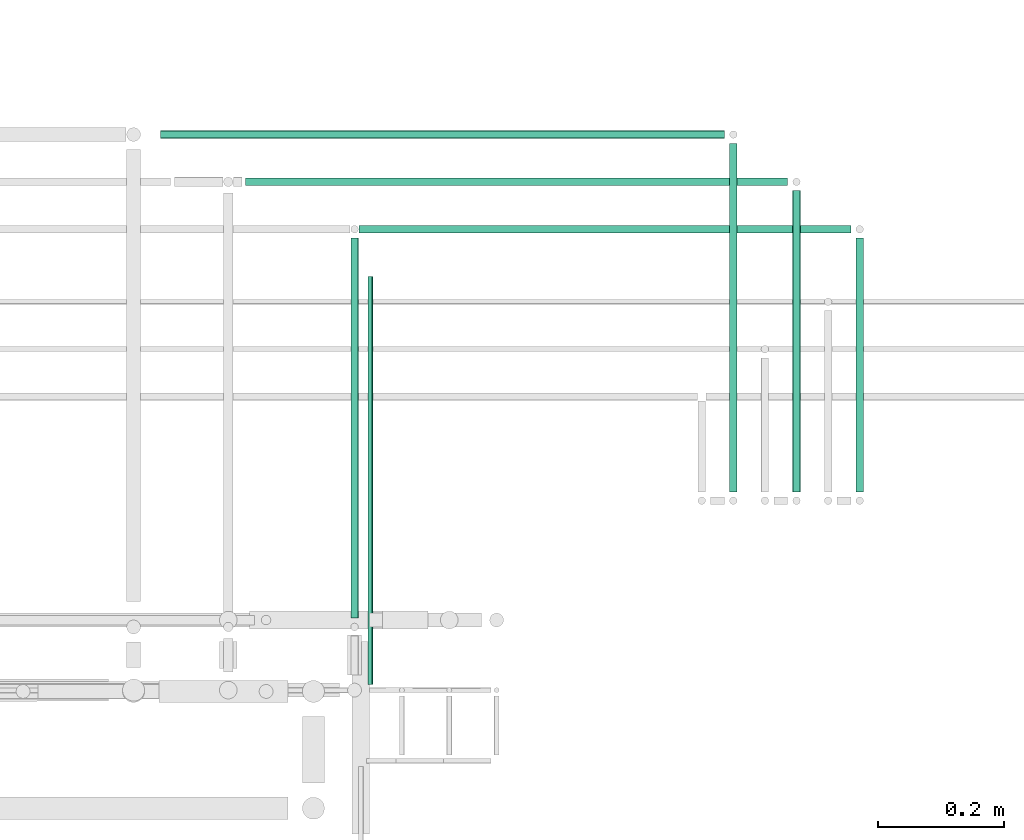
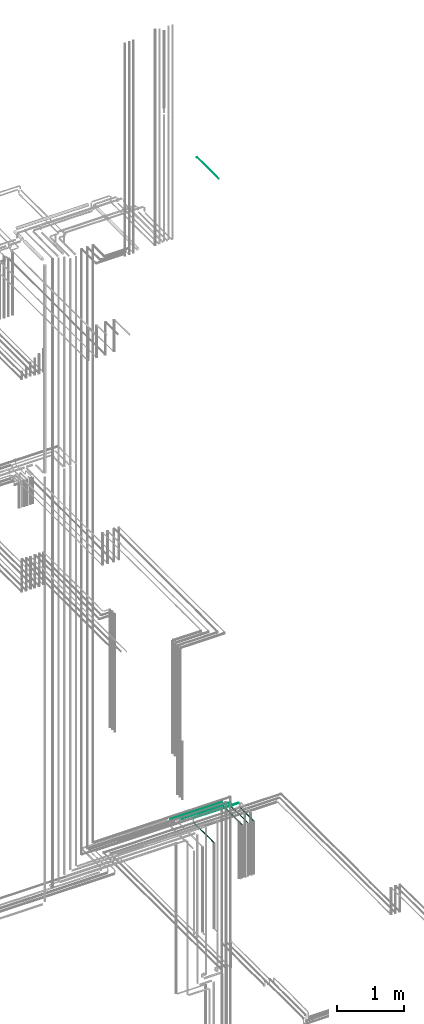
# One storey, part 236 of 331: 8 flow segments.
"""IFC2X3 building model written with IfcOpenShell, lengths in millimetres."""

from ifc_helpers import new_model, entity, si_unit, converted_unit, derived_unit, direction, frame, frame_2d, origin, origin_2d_with_axis, place, context, subcontext, project, spatial, circle, extrude, type_object, element, save


model = new_model("IFC2X3")

# Units and contexts
model_context = context("Model", 3, precision=0.01, world=origin(), true_north=direction((6.12303176911189e-17, 1.0)))
body_context = subcontext(model_context, "Body", "Model", "MODEL_VIEW")
ifc_project = project(units=[si_unit("LENGTHUNIT", "METRE", prefix="MILLI"), si_unit("AREAUNIT", "SQUARE_METRE"), si_unit("VOLUMEUNIT", "CUBIC_METRE"), converted_unit("PLANEANGLEUNIT", "DEGREE", entity("IfcRatioMeasure", 0.0174532925199433), si_unit("PLANEANGLEUNIT", "RADIAN"), dimensions=[0, 0, 0, 0, 0, 0, 0]), si_unit("MASSUNIT", "GRAM", prefix="KILO"), derived_unit("MASSDENSITYUNIT", [(si_unit("MASSUNIT", "GRAM", prefix="KILO"), 1), (si_unit("LENGTHUNIT", "METRE"), -3)]), derived_unit("MOMENTOFINERTIAUNIT", [(si_unit("LENGTHUNIT", "METRE"), 4)]), si_unit("TIMEUNIT", "SECOND"), si_unit("FREQUENCYUNIT", "HERTZ"), si_unit("THERMODYNAMICTEMPERATUREUNIT", "DEGREE_CELSIUS"), derived_unit("THERMALTRANSMITTANCEUNIT", [(si_unit("MASSUNIT", "GRAM", prefix="KILO"), 1), (si_unit("THERMODYNAMICTEMPERATUREUNIT", "KELVIN"), -1), (si_unit("TIMEUNIT", "SECOND"), -3)]), derived_unit("VOLUMETRICFLOWRATEUNIT", [(si_unit("LENGTHUNIT", "METRE"), 3), (si_unit("TIMEUNIT", "SECOND"), -1)]), derived_unit("MASSFLOWRATEUNIT", [(si_unit("MASSUNIT", "GRAM", prefix="KILO"), 1), (si_unit("TIMEUNIT", "SECOND"), -1)]), derived_unit("ROTATIONALFREQUENCYUNIT", [(si_unit("TIMEUNIT", "SECOND"), -1)]), si_unit("ELECTRICCURRENTUNIT", "AMPERE"), si_unit("ELECTRICVOLTAGEUNIT", "VOLT"), si_unit("POWERUNIT", "WATT"), si_unit("FORCEUNIT", "NEWTON", prefix="KILO"), si_unit("ILLUMINANCEUNIT", "LUX"), si_unit("LUMINOUSFLUXUNIT", "LUMEN"), si_unit("LUMINOUSINTENSITYUNIT", "CANDELA"), derived_unit("USERDEFINED", [(si_unit("MASSUNIT", "GRAM", prefix="KILO"), -1), (si_unit("LENGTHUNIT", "METRE"), -2), (si_unit("TIMEUNIT", "SECOND"), 3), (si_unit("LUMINOUSFLUXUNIT", "LUMEN"), 1)]), derived_unit("LINEARVELOCITYUNIT", [(si_unit("LENGTHUNIT", "METRE"), 1), (si_unit("TIMEUNIT", "SECOND"), -1)]), si_unit("PRESSUREUNIT", "PASCAL"), derived_unit("USERDEFINED", [(si_unit("LENGTHUNIT", "METRE"), -2), (si_unit("MASSUNIT", "GRAM", prefix="KILO"), 1), (si_unit("TIMEUNIT", "SECOND"), -2)]), derived_unit("LINEARFORCEUNIT", [(si_unit("MASSUNIT", "GRAM", prefix="KILO"), 1), (si_unit("LENGTHUNIT", "METRE"), 1), (si_unit("TIMEUNIT", "SECOND"), -2), (si_unit("LENGTHUNIT", "METRE"), -1)]), derived_unit("PLANARFORCEUNIT", [(si_unit("MASSUNIT", "GRAM", prefix="KILO"), 1), (si_unit("LENGTHUNIT", "METRE"), 1), (si_unit("TIMEUNIT", "SECOND"), -2), (si_unit("LENGTHUNIT", "METRE"), -2)])], contexts=[model_context])

# Site, building, storey
site_placement = place(None, frame((0.0, -0.00077364408347762, 0.0)))
site = spatial("IfcSite", under=ifc_project, at=site_placement, CompositionType="ELEMENT")
building_placement = place(site_placement, origin())
building = spatial("IfcBuilding", under=site, at=building_placement, CompositionType="ELEMENT")
storey_placement = place(building_placement, origin())
storey = spatial("IfcBuildingStorey", under=building, at=storey_placement, CompositionType="ELEMENT", Elevation=0.0)

# Flow segments
pipe_segment_type = type_object("IfcPipeSegmentType", PredefinedType="NOTDEFINED")
flow_segment_1_placement = place(building_placement, frame((66729.5166110417, 8159.00064239502, 18894.4047277641)))
element("IfcFlowSegment", 1, at=flow_segment_1_placement, inside=storey, type_object=pipe_segment_type, context=body_context, shape_type="SweptSolid", body=[
    extrude(circle(Radius=4.0, at=origin_2d_with_axis()), frame((5.59527223591499, 0.0, 5.59527223591499), z_axis=(0.0, 1.0, 0.0), x_axis=(1.0, 0.0, 0.0)), (0.0, 0.0, 1.0), 646.000000000004),
])
flow_segment_2_placement = place(building_placement, frame((66702.5166110417, 8264.00064239506, 6667.40472776408)))
element("IfcFlowSegment", 2, at=flow_segment_2_placement, inside=storey, type_object=pipe_segment_type, context=body_context, shape_type="SweptSolid", body=[
    extrude(circle(Radius=6.0, at=frame_2d((0.0, -1.08286712929839e-12), x_axis=(1.0, 0.0))), frame((7.59527223591454, 0.0, 7.59527223591454), z_axis=(0.0, 1.0, 0.0), x_axis=(1.0, 0.0, 0.0)), (0.0, 0.0, 1.0), 601.998493957483),
])
flow_segment_3_placement = place(building_placement, frame((66717.1118832777, 8872.40386411663, 6742.40472776408)))
element("IfcFlowSegment", 3, at=flow_segment_3_placement, inside=storey, type_object=pipe_segment_type, context=body_context, shape_type="SweptSolid", body=[
    extrude(circle(Radius=6.0, at=frame_2d((0.0, -1.08286712929839e-12), x_axis=(1.0, 0.0))), frame((0.0, 7.59527223591562, 7.59527223591454), z_axis=(1.0, 0.0, 0.0), x_axis=(0.0, -1.0, 0.0)), (0.0, 0.0, 1.0), 779.000000000022),
])
flow_segment_4_placement = place(building_placement, frame((66537.7046870151, 8947.4038641166, 6742.4047277641)))
element("IfcFlowSegment", 4, at=flow_segment_4_placement, inside=storey, type_object=pipe_segment_type, context=body_context, shape_type="SweptSolid", body=[
    extrude(circle(Radius=6.0, at=frame_2d((0.0, -1.08286712929839e-12), x_axis=(1.0, 0.0))), frame((0.0, 7.59527223591562, 7.59527223591454), z_axis=(1.0, 0.0, 0.0), x_axis=(0.0, -1.0, 0.0)), (0.0, 0.0, 1.0), 858.40719626253),
])
flow_segment_5_placement = place(building_placement, frame((66402.8776153174, 9022.40386411663, 6742.40472776409)))
element("IfcFlowSegment", 5, at=flow_segment_5_placement, inside=storey, type_object=pipe_segment_type, context=body_context, shape_type="SweptSolid", body=[
    extrude(circle(Radius=6.0, at=frame_2d((0.0, -1.08286712929839e-12), x_axis=(1.0, 0.0))), frame((0.0, 7.59527223591562, 7.59527223591454), z_axis=(1.0, 0.0, 0.0), x_axis=(0.0, -1.0, 0.0)), (0.0, 0.0, 1.0), 893.234267960246),
])
flow_segment_6_placement = place(building_placement, frame((67302.5166110417, 8463.99991607665, 6667.40472776408)))
element("IfcFlowSegment", 6, at=flow_segment_6_placement, inside=storey, type_object=pipe_segment_type, context=body_context, shape_type="SweptSolid", body=[
    extrude(circle(Radius=6.0, at=frame_2d((0.0, -1.08286712929839e-12), x_axis=(1.0, 0.0))), frame((7.59527223591454, 0.0, 7.59527223591454), z_axis=(0.0, 1.0, 0.0), x_axis=(1.0, 0.0, 0.0)), (0.0, 0.0, 1.0), 551.9992202759),
])
flow_segment_7_placement = place(building_placement, frame((67402.5166110417, 8463.99991607665, 6667.40472776408)))
element("IfcFlowSegment", 7, at=flow_segment_7_placement, inside=storey, type_object=pipe_segment_type, context=body_context, shape_type="SweptSolid", body=[
    extrude(circle(Radius=6.0, at=frame_2d((0.0, -1.08286712929839e-12), x_axis=(1.0, 0.0))), frame((7.59527223591454, 0.0, 7.59527223591454), z_axis=(0.0, 1.0, 0.0), x_axis=(1.0, 0.0, 0.0)), (0.0, 0.0, 1.0), 476.999220275889),
])
flow_segment_8_placement = place(building_placement, frame((67502.5166110417, 8463.99991607665, 6667.40472776408)))
element("IfcFlowSegment", 8, at=flow_segment_8_placement, inside=storey, type_object=pipe_segment_type, context=body_context, shape_type="SweptSolid", body=[
    extrude(circle(Radius=6.0, at=frame_2d((0.0, -1.08286712929839e-12), x_axis=(1.0, 0.0))), frame((7.59527223591454, 0.0, 7.59527223591454), z_axis=(0.0, 1.0, 0.0), x_axis=(1.0, 0.0, 0.0)), (0.0, 0.0, 1.0), 401.999220275887),
])

save(model, "model.ifc")
